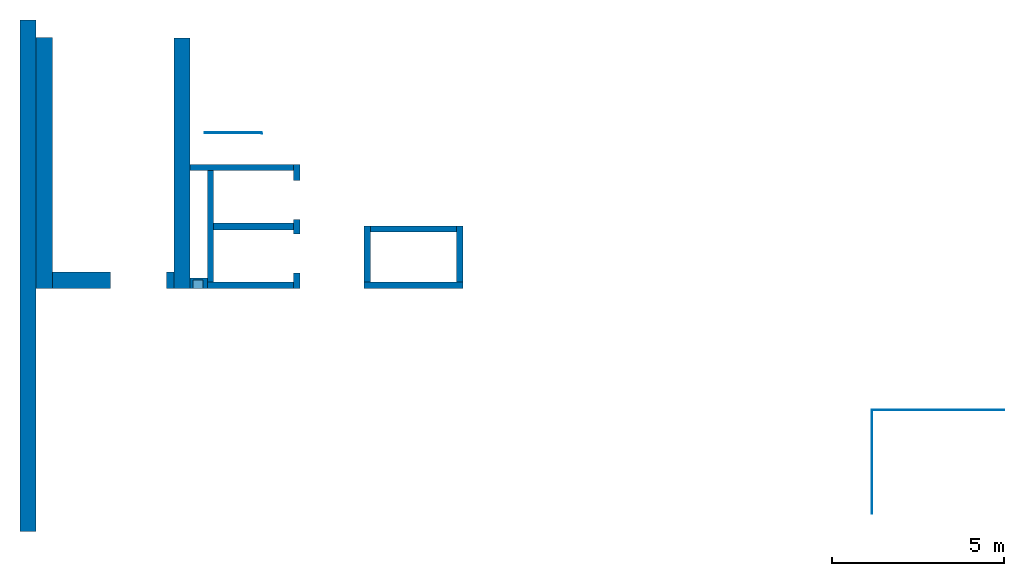
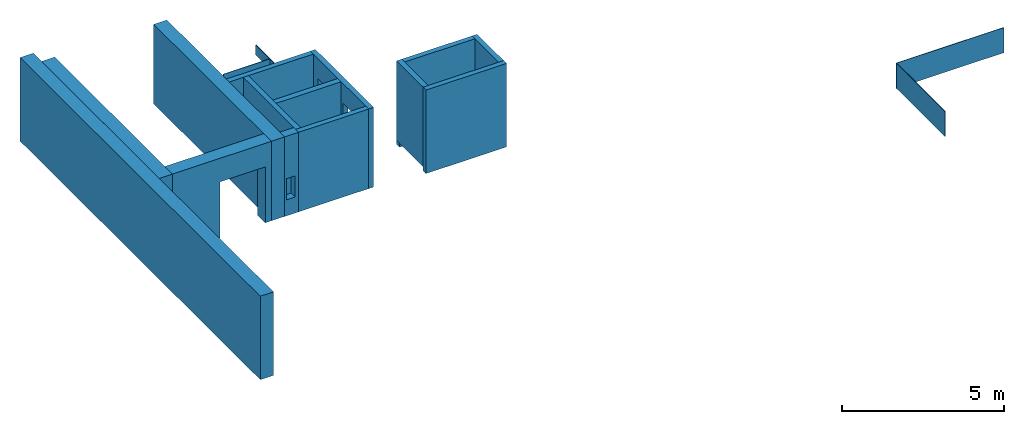
# One storey: 18 walls, 6 openings.
"""IFC4 building model written with IfcOpenShell, lengths in metres."""

import ifcopenshell
import ifcopenshell.guid

model = None  # the IFC model being written
_history = None  # IfcOwnerHistory: only IFC2X3 demands one
_inside = {}  # id of a spatial element -> (the spatial element, [elements in it])
_under = {}  # id of a project, library or spatial element -> (it, [spatial elements below it])
_declared = {}  # id of a project -> (the project, [libraries it declares])
_typed = {}  # id of a type object -> (the type object, [elements of that type])
_made_of = {}  # id of a material, layer set ... -> (it, [elements and type objects made of it])


def new_model(schema):
    """Start an empty IFC model of exactly this schema.

    Asked for "IFC4X3", IfcOpenShell would pick the latest addendum, in which some entities
    have other attributes; the version numbers below select the first issue.
    IFC2X3 requires an IfcOwnerHistory on every rooted entity: one is made here for all.
    """
    global model, _history
    if schema == "IFC4X3":
        model = ifcopenshell.file(schema_version=(4, 3, 0, 0))
    else:
        model = ifcopenshell.file(schema=schema)
    _inside.clear()
    _under.clear()
    _declared.clear()
    _typed.clear()
    _made_of.clear()
    _history = None
    if model.schema == "IFC2X3":
        org = make("IfcOrganization", Name="unknown")
        user = make(
            "IfcPersonAndOrganization",
            ThePerson=make("IfcPerson", FamilyName="unknown"),
            TheOrganization=org,
        )
        app = make(
            "IfcApplication",
            ApplicationDeveloper=org,
            Version="unknown",
            ApplicationFullName="unknown",
            ApplicationIdentifier="unknown",
        )
        _history = make(
            "IfcOwnerHistory",
            OwningUser=user,
            OwningApplication=app,
            ChangeAction="ADDED",
            CreationDate=0,
        )
    return model


def make(cls, **values):
    """One entity of the class cls with the attributes given. An attribute that is None is left unset."""
    return model.create_entity(
        cls, **{name: value for name, value in values.items() if value is not None}
    )


def entity(cls, *values):
    """Any entity or typed value of the class cls, its attributes in the order of the schema. None: left unset."""
    e = model.create_entity(cls)
    for i, value in enumerate(values):
        if value is not None:
            e[i] = value
    return e


def rooted(cls, **values):
    """An entity with a GlobalId (a new one), such as an element, a storey or a relation."""
    return make(cls, GlobalId=ifcopenshell.guid.new(), OwnerHistory=_history, **values)


def si_unit(unit_type, name, prefix=None):
    """IfcSIUnit, for example si_unit("LENGTHUNIT", "METRE", prefix="MILLI")."""
    return make("IfcSIUnit", UnitType=unit_type, Prefix=prefix, Name=name)


def converted_unit(unit_type, name, factor, base, dimensions=None, offset=None):
    """IfcConversionBasedUnit, such as the inch: factor (a typed value) times the base unit."""
    return make(
        "IfcConversionBasedUnit"
        if offset is None
        else "IfcConversionBasedUnitWithOffset",
        ConversionOffset=offset,
        Dimensions=None
        if dimensions is None
        else entity("IfcDimensionalExponents", *dimensions),
        UnitType=unit_type,
        Name=name,
        ConversionFactor=make(
            "IfcMeasureWithUnit", ValueComponent=factor, UnitComponent=base
        ),
    )


def derived_unit(unit_type, elements):
    """IfcDerivedUnit: a product of units, each with its exponent."""
    return make(
        "IfcDerivedUnit",
        Elements=[
            make("IfcDerivedUnitElement", Unit=unit, Exponent=power)
            for unit, power in elements
        ],
        UnitType=unit_type,
    )


def assignment(units):
    """IfcUnitAssignment: the units of a project."""
    return None if units is None else make("IfcUnitAssignment", Units=units)


def point(xyz):
    """IfcCartesianPoint."""
    return None if xyz is None else make("IfcCartesianPoint", Coordinates=xyz)


def direction(xyz):
    """IfcDirection."""
    return None if xyz is None else make("IfcDirection", DirectionRatios=xyz)


def frame(location, z_axis=None, x_axis=None):
    """IfcAxis2Placement3D, a coordinate frame: its origin and axes. An axis left out is left unset."""
    return make(
        "IfcAxis2Placement3D",
        Location=point(location),
        Axis=direction(z_axis),
        RefDirection=direction(x_axis),
    )


def origin_with_axes():
    """The frame at (0, 0, 0) with the z axis (0, 0, 1) and the x axis (1, 0, 0) written out."""
    return frame((0.0, 0.0, 0.0), z_axis=(0.0, 0.0, 1.0), x_axis=(1.0, 0.0, 0.0))


def place(relative_to, where):
    """IfcLocalPlacement: puts the frame where relative to a parent placement (None: the world)."""
    return make(
        "IfcLocalPlacement", PlacementRelTo=relative_to, RelativePlacement=where
    )


def context(
    kind, dimensions, precision=None, world=None, true_north=None, identifier=None
):
    """IfcGeometricRepresentationContext, for example the 3D "Model" context."""
    return make(
        "IfcGeometricRepresentationContext",
        ContextIdentifier=identifier,
        ContextType=kind,
        CoordinateSpaceDimension=dimensions,
        Precision=precision,
        WorldCoordinateSystem=world,
        TrueNorth=true_north,
    )


def subcontext(parent, identifier, kind, view, scale=None):
    """IfcGeometricRepresentationSubContext, for example "Body" below "Model"."""
    return make(
        "IfcGeometricRepresentationSubContext",
        ContextIdentifier=identifier,
        ContextType=kind,
        ParentContext=parent,
        TargetScale=scale,
        TargetView=view,
    )


def project(units=None, contexts=None):
    """IfcProject with its units and contexts."""
    return rooted(
        "IfcProject",
        Name="project",
        RepresentationContexts=contexts,
        UnitsInContext=assignment(units),
    )


def spatial(cls, under=None, at=None, **own):
    """A site, building, storey or space (cls), placed at a placement, below another one or the project."""
    s = rooted(cls, ObjectPlacement=at, **own)
    if under is not None:
        _under.setdefault(under.id(), (under, []))[1].append(s)
    return s


def point_list(points):
    """IfcCartesianPointList2D or 3D."""
    cls = (
        "IfcCartesianPointList2D" if len(points[0]) == 2 else "IfcCartesianPointList3D"
    )
    return make(cls, CoordList=points)


def polygons(points, faces, closed=None, point_numbers=None):
    """IfcPolygonalFaceSet: a face is its outer loop, then its inner loops; points numbered from 1."""
    made = []
    for loops in faces:
        if len(loops) == 1:
            made.append(make("IfcIndexedPolygonalFace", CoordIndex=loops[0]))
        else:
            made.append(
                make(
                    "IfcIndexedPolygonalFaceWithVoids",
                    CoordIndex=loops[0],
                    InnerCoordIndices=loops[1:],
                )
            )
    return make(
        "IfcPolygonalFaceSet",
        Coordinates=point_list(points),
        Closed=closed,
        Faces=made,
        PnIndex=point_numbers,
    )


def shape(context_of_items, identifier, shape_type, items):
    """IfcShapeRepresentation: the items that make up one representation, for example the "Body"."""
    return make(
        "IfcShapeRepresentation",
        ContextOfItems=context_of_items,
        RepresentationIdentifier=identifier,
        RepresentationType=shape_type,
        Items=items,
    )


def material(Name=None, Category=None):
    """IfcMaterial."""
    return make("IfcMaterial", Name=Name, Category=Category)


def made_of(thing, what):
    """Note that an element or type object is made of a material, layer set ...; save() writes the relation."""
    if what is not None:
        _made_of.setdefault(what.id(), (what, []))[1].append(thing)
    return thing


def type_object(cls, material=None, **own):
    """A type object (cls), such as IfcWallType, which elements share."""
    return made_of(rooted(cls, **own), material)


def element(
    cls,
    number,
    at=None,
    inside=None,
    cuts=None,
    type_object=None,
    material=None,
    context=None,
    identifier="Body",
    shape_type=None,
    held_by="IfcProductDefinitionShape",
    body=None,
    shapes=None,
    **own,
):
    """One element of the class cls, such as IfcWall. Its Tag is "e" and its number.

    at: its placement. inside: the storey or other place that contains it. cuts: it is an
    opening in that element (IfcRelVoidsElement). A single representation is given by context,
    identifier, shape_type and body (its items); several are given by shapes. held_by: the class
    of the entity that holds the representations. save() writes the other relations.
    """
    e = rooted(cls, Tag="e%d" % number, ObjectPlacement=at, **own)
    if body is not None:
        shapes = [shape(context, identifier, shape_type, body)]
    if shapes is not None:
        e.Representation = make(held_by, Representations=shapes)
    if inside is not None:
        _inside.setdefault(inside.id(), (inside, []))[1].append(e)
    if cuts is not None:
        rooted(
            "IfcRelVoidsElement", RelatingBuildingElement=cuts, RelatedOpeningElement=e
        )
    if type_object is not None:
        _typed.setdefault(type_object.id(), (type_object, []))[1].append(e)
    return made_of(e, material)


def aggregate(whole, parts):
    """IfcRelAggregates: a whole, such as a stair, and the parts it consists of."""
    return rooted("IfcRelAggregates", RelatingObject=whole, RelatedObjects=parts)


def save(model, path):
    """Write the relations noted so far, then the file.

    IfcRelAggregates (storeys below a building ...), IfcRelContainedInSpatialStructure (elements
    in a storey), IfcRelDefinesByType, IfcRelAssociatesMaterial and IfcRelDeclares: one each for
    every whole, place, type object, material and project.
    """
    for whole, parts in _under.values():
        aggregate(whole, parts)
    for where, things in _inside.values():
        rooted(
            "IfcRelContainedInSpatialStructure",
            RelatedElements=things,
            RelatingStructure=where,
        )
    for kind, things in _typed.values():
        rooted("IfcRelDefinesByType", RelatedObjects=things, RelatingType=kind)
    for what, things in _made_of.values():
        rooted("IfcRelAssociatesMaterial", RelatedObjects=things, RelatingMaterial=what)
    for by, libraries in _declared.values():
        rooted("IfcRelDeclares", RelatingContext=by, RelatedDefinitions=libraries)
    model.write(path)


model = new_model("IFC4")

# Units and contexts
model_context = context("Model", 3, precision=1e-05, world=origin_with_axes(), true_north=direction((0.0, 1.0)))
body_context = subcontext(model_context, "Body", "Model", "MODEL_VIEW")
ifc_project = project(units=[si_unit("LENGTHUNIT", "METRE"), si_unit("AREAUNIT", "SQUARE_METRE"), si_unit("VOLUMEUNIT", "CUBIC_METRE"), converted_unit("PLANEANGLEUNIT", "DEGREE", entity("IfcPlaneAngleMeasure", 0.0174532925199433), si_unit("PLANEANGLEUNIT", "RADIAN"), dimensions=[0, 0, 0, 0, 0, 0, 0]), converted_unit("TIMEUNIT", "Year", entity("IfcTimeMeasure", 31557600.0), si_unit("TIMEUNIT", "SECOND"), dimensions=[0, 0, 1, 0, 0, 0, 0]), si_unit("MASSUNIT", "GRAM", prefix="KILO"), si_unit("THERMODYNAMICTEMPERATUREUNIT", "DEGREE_CELSIUS"), si_unit("LUMINOUSINTENSITYUNIT", "LUMEN"), si_unit("ENERGYUNIT", "JOULE", prefix="MEGA"), derived_unit("THERMALCONDUCTANCEUNIT", [(si_unit("POWERUNIT", "WATT"), 1), (si_unit("LENGTHUNIT", "METRE"), -1), (si_unit("THERMODYNAMICTEMPERATUREUNIT", "KELVIN"), -1)]), derived_unit("SPECIFICHEATCAPACITYUNIT", [(si_unit("ENERGYUNIT", "JOULE"), 1), (si_unit("MASSUNIT", "GRAM", prefix="KILO"), -1), (si_unit("THERMODYNAMICTEMPERATUREUNIT", "KELVIN"), -1)]), derived_unit("MASSDENSITYUNIT", [(si_unit("MASSUNIT", "GRAM", prefix="KILO"), 1), (si_unit("VOLUMEUNIT", "CUBIC_METRE"), -1)])], contexts=[model_context])

# Site, building, storey
site_placement = place(None, origin_with_axes())
site = spatial("IfcSite", under=ifc_project, at=site_placement, CompositionType="ELEMENT")
building_placement = place(None, origin_with_axes())
building = spatial("IfcBuilding", under=site, at=building_placement, CompositionType="ELEMENT")
storey_placement = place(None, frame((0.0, 0.0, 4.5), z_axis=(0.0, 0.0, 1.0), x_axis=(1.0, 0.0, 0.0)))
storey = spatial("IfcBuildingStorey", under=building, at=storey_placement, Name="1 OG", CompositionType="ELEMENT", Elevation=4.5)

# Walls
ifc_material_1 = material(Name="Stahlbeton")
wall_type_1 = type_object("IfcWallType", Name="Stahlbeton 180", PredefinedType="NOTDEFINED")
wall_1_placement = place(None, frame((36.373, 7.05499994546756, 4.5), z_axis=(0.0, 0.0, 1.0), x_axis=(0.0, 1.0, 0.0)))
element("IfcWall", 1, at=wall_1_placement, inside=storey, type_object=wall_type_1, material=ifc_material_1, Name="Wand-001", PredefinedType="NOTDEFINED", context=body_context, shape_type="Tessellation", body=[
    polygons([(1.818, 0.18, 0.0), (1.818, 0.0, 0.0), (0.18, 0.0, 0.0), (0.18, 0.18, 0.0), (1.818, 0.18, 3.0), (1.818, 0.0, 3.0), (0.18, 0.0, 3.0), (0.18, 0.18, 3.0)], [[[1, 2, 3, 4]], [[2, 1, 5, 6]], [[2, 6, 7, 3]], [[8, 4, 3, 7]], [[5, 1, 4, 8]], [[6, 5, 8, 7]]], closed=True),
])
wall_2_placement = place(None, frame((28.958, 7.05499994546755, 4.5), z_axis=(0.0, 0.0, 1.0), x_axis=(1.0, 0.0, 0.0)))
element("IfcWall", 2, at=wall_2_placement, inside=storey, type_object=wall_type_1, material=ifc_material_1, Name="Wand-001", PredefinedType="NOTDEFINED", context=body_context, shape_type="Tessellation", body=[
    polygons([(2.5, 0.180000000000001, 0.0), (2.5, 0.0, 0.0), (0.0, 0.0, 0.0), (0.0, 0.18, 0.0), (2.5, 0.180000000000001, 3.0), (2.5, 0.0, 3.0), (0.0, 0.0, 3.0), (0.0, 0.180000000000001, 3.0)], [[[1, 2, 3, 4]], [[2, 1, 5, 6]], [[2, 6, 7, 3]], [[8, 4, 3, 7]], [[5, 1, 4, 8]], [[6, 5, 8, 7]]], closed=True),
])
wall_3_placement = place(None, frame((33.505, 7.05499994546756, 4.5), z_axis=(0.0, 0.0, 1.0), x_axis=(0.0, 1.0, 0.0)))
element("IfcWall", 3, at=wall_3_placement, inside=storey, type_object=wall_type_1, material=ifc_material_1, Name="Wand-001", PredefinedType="NOTDEFINED", context=body_context, shape_type="Tessellation", body=[
    polygons([(1.818, -0.18, 3.0), (1.818, 0.0, 3.0), (0.18, 0.0, 3.0), (0.18, -0.18, 3.0), (1.818, -0.18, 0.0), (1.818, 0.0, 0.0), (0.18, 0.0, 0.0), (0.18, -0.18, 0.0)], [[[1, 2, 3, 4]], [[2, 1, 5, 6]], [[2, 6, 7, 3]], [[8, 4, 3, 7]], [[5, 1, 4, 8]], [[6, 5, 8, 7]]], closed=True),
])

# Wall, openings
wall_4_placement = place(None, frame((31.638, 7.05499994546755, 4.5), z_axis=(0.0, 0.0, 1.0), x_axis=(0.0, 1.0, 0.0)))
wall_4 = element("IfcWall", 4, at=wall_4_placement, inside=storey, type_object=wall_type_1, material=ifc_material_1, Name="Wand-002", PredefinedType="NOTDEFINED", context=body_context, shape_type="Tessellation", body=[
    polygons([(2.0, 0.0, 0.0), (2.0, 0.0, 2.25), (3.13, 0.0, 2.25), (3.13, 0.0, 0.0), (3.6, 0.0, 0.0), (3.6, 0.0, 3.0), (0.0, 0.0, 3.0), (0.0, 0.0, 0.0), (0.450000000000002, 0.0, 0.0), (0.450000000000002, 0.0, 2.25), (1.58, 0.0, 2.25), (1.58, 0.0, 0.0), (2.0, 0.179999999999996, 0.0), (2.0, 0.179999999999996, 2.25), (3.13, 0.179999999999996, 2.25), (3.13, 0.179999999999996, 0.0), (3.6, 0.179999999999996, 0.0), (3.6, 0.179999999999996, 3.0), (0.0, 0.18, 3.0), (0.0, 0.18, 0.0), (0.450000000000002, 0.18, 0.0), (0.450000000000002, 0.18, 2.25), (1.58, 0.18, 2.25), (1.58, 0.18, 0.0)], [[[1, 2, 3, 4, 5, 6, 7, 8, 9, 10, 11, 12]], [[2, 1, 13, 14]], [[3, 2, 14, 15]], [[4, 3, 15, 16]], [[4, 16, 17, 5]], [[18, 6, 5, 17]], [[19, 7, 6, 18]], [[8, 7, 19, 20]], [[9, 8, 20, 21]], [[9, 21, 22, 10]], [[10, 22, 23, 11]], [[11, 23, 24, 12]], [[13, 1, 12, 24]], [[14, 13, 24, 23, 22, 21, 20, 19, 18, 17, 16, 15]]], closed=True),
])
opening_1_placement = place(wall_4_placement, frame((1.015, 0.0, 0.0), z_axis=(0.0, 0.0, 1.0), x_axis=(1.0, 0.0, 0.0)))
element("IfcOpeningElement", 5, at=opening_1_placement, cuts=wall_4, context=body_context, identifier="Reference", shape_type="Tessellation", body=[
    polygons([(-0.565, -0.00100000000000122, 2.25), (-0.565, -0.00100000000000122, 0.0), (0.565, -0.00100000000000122, 0.0), (0.565, -0.00100000000000122, 2.25), (-0.565, 0.181000000000004, 2.25), (-0.565, 0.181000000000004, 0.0), (0.565000000000001, 0.181000000000004, 0.0), (0.565000000000001, 0.181000000000004, 2.25)], [[[1, 2, 3, 4]], [[5, 6, 2, 1]], [[6, 7, 3, 2]], [[7, 8, 4, 3]], [[8, 5, 1, 4]], [[7, 6, 5, 8]]], closed=True),
])
opening_2_placement = place(wall_4_placement, frame((2.565, 0.0, 0.0), z_axis=(0.0, 0.0, 1.0), x_axis=(1.0, 0.0, 0.0)))
element("IfcOpeningElement", 6, at=opening_2_placement, cuts=wall_4, context=body_context, identifier="Reference", shape_type="Tessellation", body=[
    polygons([(-0.565, -0.00100000000000478, 2.25), (-0.565, -0.00100000000000478, 0.0), (0.565, -0.00100000000000478, 0.0), (0.565, -0.00100000000000478, 2.25), (-0.564999999999998, 0.181000000000001, 2.25), (-0.564999999999998, 0.181000000000001, 0.0), (0.565000000000001, 0.181000000000001, 0.0), (0.565000000000001, 0.181000000000001, 2.25)], [[[1, 2, 3, 4]], [[5, 6, 2, 1]], [[6, 7, 3, 2]], [[7, 8, 4, 3]], [[8, 5, 1, 4]], [[7, 6, 5, 8]]], closed=True),
])

# Walls
wall_5_placement = place(None, frame((31.638, 10.6549999454676, 4.5), z_axis=(0.0, 0.0, 1.0), x_axis=(-1.0, 0.0, 0.0)))
element("IfcWall", 7, at=wall_5_placement, inside=storey, type_object=wall_type_1, material=ifc_material_1, Name="Wand-003", PredefinedType="NOTDEFINED", context=body_context, shape_type="Tessellation", body=[
    polygons([(3.18, 0.18, 0.0), (3.18, 0.0, 0.0), (0.18, 0.0, 0.0), (0.18, 0.18, 0.0), (3.18, 0.18, 3.0), (3.18, 0.0, 3.0), (0.18, 0.0, 3.0), (0.18, 0.18, 3.0)], [[[1, 2, 3, 4]], [[2, 1, 5, 6]], [[2, 6, 7, 3]], [[8, 4, 3, 7]], [[5, 1, 4, 8]], [[6, 5, 8, 7]]], closed=True),
])
wall_6_placement = place(None, frame((36.373, 8.87299994546756, 4.35), z_axis=(0.0, 0.0, 1.0), x_axis=(-1.0, 0.0, 0.0)))
element("IfcWall", 8, at=wall_6_placement, inside=storey, type_object=wall_type_1, material=ifc_material_1, Name="Wand-001", PredefinedType="NOTDEFINED", context=body_context, shape_type="Tessellation", body=[
    polygons([(2.688, 0.0, 3.15), (0.18, 0.0, 3.15), (0.18, 0.0, 0.15), (0.0, 0.0, 0.15), (0.0, 0.0, 0.0), (2.868, 0.0, 0.0), (2.868, 0.0, 0.15), (2.688, 0.0, 0.15), (2.688, 0.18, 3.15), (0.18, 0.18, 3.15), (0.18, 0.18, 0.15), (0.0, 0.18, 0.15), (0.0, 0.18, 0.0), (2.868, 0.18, 0.0), (2.868, 0.18, 0.15), (2.688, 0.18, 0.15)], [[[1, 2, 3, 4, 5, 6, 7, 8]], [[9, 10, 2, 1]], [[11, 3, 2, 10]], [[11, 12, 4, 3]], [[5, 4, 12, 13]], [[5, 13, 14, 6]], [[14, 15, 7, 6]], [[16, 8, 7, 15]], [[16, 9, 1, 8]], [[12, 11, 10, 9, 16, 15, 14, 13]]], closed=True),
])
wall_7_placement = place(None, frame((33.505, 7.05499994546756, 4.35), z_axis=(0.0, 0.0, 1.0), x_axis=(1.0, 0.0, 0.0)))
element("IfcWall", 9, at=wall_7_placement, inside=storey, type_object=wall_type_1, material=ifc_material_1, Name="Wand-001", PredefinedType="NOTDEFINED", context=body_context, shape_type="Tessellation", body=[
    polygons([(2.868, 0.0, 3.15), (2.868, 0.0, 0.15), (2.868, 0.18, 0.15), (2.868, 0.180000000000001, 3.15), (0.0, 0.0, 0.0), (2.868, 0.0, 0.0), (0.0, 0.0, 3.15), (0.0, 0.0, 0.15), (2.868, 0.18, 0.0), (0.0, 0.18, 0.0), (0.0, 0.18, 0.15), (0.0, 0.180000000000001, 3.15)], [[[1, 2, 3, 4]], [[5, 6, 2, 1, 7, 8]], [[6, 9, 3, 2]], [[4, 3, 9, 10, 11, 12]], [[7, 1, 4, 12]], [[10, 9, 6, 5]], [[12, 11, 8, 7]], [[5, 8, 11, 10]]], closed=True),
])
wall_8_placement = place(None, frame((29.138, 7.05499994546755, 4.5), z_axis=(0.0, 0.0, 1.0), x_axis=(0.0, 1.0, 0.0)))
element("IfcWall", 10, at=wall_8_placement, inside=storey, type_object=wall_type_1, material=ifc_material_1, Name="Wand-003", PredefinedType="NOTDEFINED", context=body_context, shape_type="Tessellation", body=[
    polygons([(3.42, 0.18, 0.0), (3.42, 0.0, 0.0), (0.18, 0.0, 0.0), (0.18, 0.18, 0.0), (3.42, 0.18, 3.0), (3.42, 0.0, 3.0), (0.18, 0.0, 3.0), (0.18, 0.18, 3.0)], [[[1, 2, 3, 4]], [[2, 1, 5, 6]], [[2, 6, 7, 3]], [[8, 4, 3, 7]], [[5, 1, 4, 8]], [[6, 5, 8, 7]]], closed=True),
])

# Space
space_placement = place(None, frame((28.883, 12.4404999136732, 4.5), z_axis=(0.0, 0.0, 1.0), x_axis=(0.0, -1.0, 0.0)))
space = spatial("IfcSpace", under=storey, at=space_placement, CompositionType="ELEMENT", PredefinedType="NOTDEFINED")

# Wall, openings
ifc_material_2 = material(Name="Kunststoff")
wall_type_2 = type_object("IfcWallType", Name="Kunststoff 20", PredefinedType="NOTDEFINED")
wall_9_placement = place(None, frame((30.553, 10.6549999454676, 4.35), z_axis=(0.0, 0.0, 1.0), x_axis=(0.0, 1.0, 0.0)))
wall_9 = element("IfcWall", 11, at=wall_9_placement, inside=space, type_object=wall_type_2, material=ifc_material_2, Name="Wand-003", PredefinedType="NOTDEFINED", context=body_context, shape_type="Tessellation", body=[
    polygons([(0.895499968205613, 0.0, 0.15), (0.895499968205613, 0.0, 2.245), (1.78549996820561, 0.0, 2.245), (1.78549996820561, 0.0, 2.63), (0.0, 0.0, 2.63), (0.0, 0.0, 2.245), (0.890000000000001, 0.0, 2.245), (0.890000000000001, 0.0, 0.15), (0.895499968205613, 0.0199999999999996, 0.15), (0.895499968205613, 0.0199999999999996, 2.245), (1.78549996820561, 0.0199999999999996, 2.245), (1.78549996820561, 0.0199999999999996, 2.63), (0.0, 0.0199999999999996, 2.63), (0.0, 0.0199999999999996, 2.245), (0.890000000000001, 0.0199999999999996, 2.245), (0.890000000000001, 0.0199999999999996, 0.15)], [[[1, 2, 3, 4, 5, 6, 7, 8]], [[2, 1, 9, 10]], [[11, 3, 2, 10]], [[3, 11, 12, 4]], [[13, 5, 4, 12]], [[6, 5, 13, 14]], [[6, 14, 15, 7]], [[7, 15, 16, 8]], [[9, 1, 8, 16]], [[10, 9, 16, 15, 14, 13, 12, 11]]], closed=True),
])
opening_3_placement = place(wall_9_placement, frame((1.34049996820561, 0.0, 0.2), z_axis=(0.0, 0.0, 1.0), x_axis=(1.0, 0.0, 0.0)))
element("IfcOpeningElement", 12, at=opening_3_placement, cuts=wall_9, context=body_context, identifier="Reference", shape_type="Tessellation", body=[
    polygons([(0.445, 0.0210000000000008, 2.045), (0.445, 0.0210000000000008, -0.0499999999999998), (-0.445, 0.0210000000000008, -0.0499999999999998), (-0.445, 0.0210000000000008, 2.045), (0.445, -0.00100000000000122, 2.045), (0.445, -0.00100000000000122, -0.0499999999999998), (-0.445, -0.00100000000000122, -0.0499999999999998), (-0.445, -0.00100000000000122, 2.045)], [[[1, 2, 3, 4]], [[5, 6, 2, 1]], [[6, 7, 3, 2]], [[7, 8, 4, 3]], [[8, 5, 1, 4]], [[7, 6, 5, 8]]], closed=True),
])
opening_4_placement = place(wall_9_placement, frame((0.445, 0.0, 0.2), z_axis=(0.0, 0.0, 1.0), x_axis=(1.0, 0.0, 0.0)))
element("IfcOpeningElement", 13, at=opening_4_placement, cuts=wall_9, context=body_context, identifier="Reference", shape_type="Tessellation", body=[
    polygons([(0.445, 0.0210000000000008, 2.045), (0.445, 0.0210000000000008, -0.0499999999999998), (-0.445, 0.0210000000000008, -0.0499999999999998), (-0.445, 0.0210000000000008, 2.045), (0.445, -0.00100000000000122, 2.045), (0.445, -0.00100000000000122, -0.0499999999999998), (-0.445, -0.00100000000000122, -0.0499999999999998), (-0.445, -0.00100000000000122, 2.045)], [[[1, 2, 3, 4]], [[5, 6, 2, 1]], [[6, 7, 3, 2]], [[7, 8, 4, 3]], [[8, 5, 1, 4]], [[7, 6, 5, 8]]], closed=True),
])

# Walls
wall_10_placement = place(None, frame((30.553, 11.5727499295704, 4.35), z_axis=(0.0, 0.0, 1.0), x_axis=(-1.0, 0.0, 0.0)))
element("IfcWall", 14, at=wall_10_placement, inside=space, type_object=wall_type_2, material=ifc_material_2, Name="Wand-003", PredefinedType="NOTDEFINED", context=body_context, shape_type="Tessellation", body=[
    polygons([(0.0199999999999996, -0.00999999999999979, 2.63), (0.0199999999999996, 0.00999999999999979, 2.63), (0.0199999999999996, 0.00999999999999979, 0.15), (0.0199999999999996, -0.00999999999999979, 0.15), (1.67, -0.00999999999999979, 2.63), (1.67, 0.00999999999999979, 2.63), (1.67, 0.00999999999999979, 0.15), (1.67, -0.00999999999999979, 0.15)], [[[1, 2, 3, 4]], [[2, 1, 5, 6]], [[2, 6, 7, 3]], [[3, 7, 8, 4]], [[5, 1, 4, 8]], [[6, 5, 8, 7]]], closed=True),
])
wall_type_3 = type_object("IfcWallType", Name="Stahlbeton 470", PredefinedType="NOTDEFINED")
wall_11_placement = place(None, frame((23.988, 14.8459998818788, 4.35), z_axis=(0.0, 0.0, 1.0), x_axis=(0.0, -1.0, 0.0)))
element("IfcWall", 15, at=wall_11_placement, inside=storey, type_object=wall_type_3, material=ifc_material_1, Name="Wand-001", PredefinedType="NOTDEFINED", context=body_context, shape_type="Tessellation", body=[
    polygons([(0.0, 0.0, 0.0), (0.0, 0.0, 3.15), (14.8459998818788, 0.0, 3.15), (14.8459998818788, 0.0, 0.0), (0.362999951604566, 0.0, 3.0), (0.362999951604566, 0.0, 2.63), (7.79099993641123, 0.0, 2.63), (14.4829998291425, 0.0, 2.63), (14.4829998291425, 0.0, 3.0), (7.79099993641123, 0.0, 3.0), (0.0, -0.469999999999999, 0.0), (0.0, -0.469999999999999, 3.15), (14.8459998818788, -0.469999999999999, 3.15), (14.8459998818788, -0.469999999999999, 0.0), (0.362999951604566, -0.100000000000008, 2.63), (0.362999951604566, -0.100000000000008, 3.0), (14.4829998289544, -0.100000000000008, 2.63), (14.4829998289544, -0.100000000000008, 3.0)], [[[1, 2, 3, 4], [5, 6, 7, 8, 9, 10]], [[1, 11, 12, 2]], [[2, 12, 13, 3]], [[4, 3, 13, 14]], [[11, 1, 4, 14]], [[15, 6, 5, 16]], [[8, 7, 6, 15, 17]], [[18, 9, 8, 17]], [[18, 16, 5, 10, 9]], [[12, 11, 14, 13]], [[17, 15, 16, 18]]], closed=True),
])
wall_12_placement = place(None, frame((27.988, 14.3259998818788, 4.5), z_axis=(0.0, 0.0, 1.0), x_axis=(0.0, -1.0, 0.0)))
element("IfcWall", 16, at=wall_12_placement, inside=storey, type_object=wall_type_3, material=ifc_material_1, Name="Wand-001", PredefinedType="NOTDEFINED", context=body_context, shape_type="Tessellation", body=[
    polygons([(7.27099993641123, 0.469999999999999, 0.0), (7.27099993641123, 0.0, 0.0), (0.0, 0.0, 0.0), (0.0, 0.469999999999999, 0.0), (7.27099993641123, 0.469999999999999, 3.0), (7.27099993641123, 0.0, 3.0), (0.0, 0.0, 3.0), (0.0, 0.469999999999999, 3.0)], [[[1, 2, 3, 4]], [[2, 1, 5, 6]], [[2, 6, 7, 3]], [[8, 4, 3, 7]], [[5, 1, 4, 8]], [[6, 5, 8, 7]]], closed=True),
])

# Wall, opening
wall_13_placement = place(None, frame((24.458, 7.52499994546755, 4.5), z_axis=(0.0, 0.0, 1.0), x_axis=(1.0, 0.0, 0.0)))
wall_13 = element("IfcWall", 17, at=wall_13_placement, inside=storey, type_object=wall_type_3, material=ifc_material_1, Name="Wand-001", PredefinedType="NOTDEFINED", context=body_context, shape_type="Tessellation", body=[
    polygons([(1.69000000000001, 0.0, 2.11), (1.69000000000001, 0.0, 0.0), (0.0, 0.0, 0.0), (0.0, 0.0, 3.0), (3.53, 0.0, 3.0), (3.53, 0.0, 0.0), (3.31, 0.0, 0.0), (3.31, 0.0, 2.11), (1.69000000000001, -0.47, 2.11), (1.69000000000001, -0.47, 0.0), (0.0, -0.47, 0.0), (0.0, -0.47, 3.0), (3.53, -0.47, 3.0), (3.53, -0.47, 0.0), (3.31, -0.47, 0.0), (3.31, -0.47, 2.11)], [[[1, 2, 3, 4, 5, 6, 7, 8]], [[2, 1, 9, 10]], [[2, 10, 11, 3]], [[12, 4, 3, 11]], [[5, 4, 12, 13]], [[13, 14, 6, 5]], [[15, 7, 6, 14]], [[8, 7, 15, 16]], [[1, 8, 16, 9]], [[16, 15, 14, 13, 12, 11, 10, 9]]], closed=True),
])
opening_5_placement = place(wall_13_placement, frame((2.5, 0.0, 0.0), z_axis=(0.0, 0.0, 1.0), x_axis=(1.0, 0.0, 0.0)))
element("IfcOpeningElement", 18, at=opening_5_placement, cuts=wall_13, context=body_context, identifier="Reference", shape_type="Tessellation", body=[
    polygons([(-0.809999999999999, -0.471, 2.11), (-0.809999999999999, -0.471, 0.0), (0.809999999999999, -0.471, 0.0), (0.809999999999999, -0.471, 2.11), (-0.809999999999999, 0.00100000000000033, 2.11), (-0.809999999999999, 0.00100000000000033, 0.0), (0.809999999999999, 0.00100000000000033, 0.0), (0.809999999999999, 0.00100000000000033, 2.11)], [[[1, 2, 3, 4]], [[5, 6, 2, 1]], [[6, 7, 3, 2]], [[7, 8, 4, 3]], [[8, 5, 1, 4]], [[7, 6, 5, 8]]], closed=True),
])

# Wall
wall_14_placement = place(None, frame((24.458, 14.3318657372406, 4.5), z_axis=(0.0, 0.0, 1.0), x_axis=(0.0, -1.0, 0.0)))
element("IfcWall", 19, at=wall_14_placement, inside=storey, type_object=wall_type_3, material=ifc_material_1, Name="Wand-001", PredefinedType="NOTDEFINED", context=body_context, shape_type="Tessellation", body=[
    polygons([(7.27686579177299, -0.470000000000002, 3.0), (7.27686579177299, 0.0, 3.0), (0.0, 0.0, 3.0), (0.0, -0.469999999999999, 3.0), (7.27686579177299, -0.470000000000002, 0.0), (7.27686579177299, 0.0, 0.0), (0.0, 0.0, 0.0), (0.0, -0.469999999999999, 0.0)], [[[1, 2, 3, 4]], [[2, 1, 5, 6]], [[2, 6, 7, 3]], [[8, 4, 3, 7]], [[5, 1, 4, 8]], [[6, 5, 8, 7]]], closed=True),
])

# Wall, opening
wall_type_4 = type_object("IfcWallType", Name="Stahlbeton 300", PredefinedType="NOTDEFINED")
wall_15_placement = place(None, frame((28.458, 7.05499994546755, 4.5), z_axis=(0.0, 0.0, 1.0), x_axis=(1.0, 0.0, 0.0)))
wall_15 = element("IfcWall", 20, at=wall_15_placement, inside=storey, type_object=wall_type_4, material=ifc_material_1, Name="Wand-001", PredefinedType="NOTDEFINED", context=body_context, shape_type="Tessellation", body=[
    polygons([(0.0, 0.0, 3.0), (0.0, 0.0, 0.0), (0.5, 0.0, 0.0), (0.5, 0.0, 3.0), (0.375425898351669, 0.0, 0.6), (0.0754258983516713, 0.0, 0.6), (0.0754258983516713, 0.0, 1.4), (0.375425898351669, 0.0, 1.4), (0.0, 0.3, 3.0), (0.0, 0.3, 0.0), (0.5, 0.3, 0.0), (0.5, 0.3, 3.0), (0.0754258983516713, 0.25, 0.6), (0.375425898351669, 0.25, 0.6), (0.0754258983516713, 0.25, 1.4), (0.375425898351669, 0.25, 1.4)], [[[1, 2, 3, 4], [5, 6, 7, 8]], [[1, 9, 10, 2]], [[2, 10, 11, 3]], [[4, 3, 11, 12]], [[9, 1, 4, 12]], [[13, 6, 5, 14]], [[15, 7, 6, 13]], [[16, 8, 7, 15]], [[14, 5, 8, 16]], [[10, 9, 12, 11]], [[13, 14, 16, 15]]], closed=True),
])
opening_6_placement = place(wall_15_placement, frame((-28.458, -7.05499994546755, -4.5), z_axis=(0.0, 0.0, 1.0), x_axis=(1.0, 0.0, 0.0)))
element("IfcOpeningElement", 21, at=opening_6_placement, cuts=wall_15, PredefinedType="NOTDEFINED", context=body_context, identifier="Reference", shape_type="Tessellation", body=[
    polygons([(28.5334258983517, 7.30499994546755, 5.1), (28.8334258983517, 7.30499994546755, 5.1), (28.8334258983517, 6.75499994546755, 5.1), (28.5334258983517, 6.75499994546755, 5.1), (28.5334258983517, 7.30499994546755, 5.9), (28.8334258983517, 7.30499994546755, 5.9), (28.8334258983517, 6.75499994546755, 5.9), (28.5334258983517, 6.75499994546755, 5.9)], [[[1, 2, 3, 4]], [[1, 5, 6, 2]], [[2, 6, 7, 3]], [[4, 3, 7, 8]], [[5, 1, 4, 8]], [[6, 5, 8, 7]]], closed=True),
])

# Walls
ifc_material_3 = material()
wall_type_5 = type_object("IfcWallType", Name="20", PredefinedType="NOTDEFINED")
wall_16_placement = place(None, frame((52.078, 3.52, 4.55), z_axis=(0.0, 0.0, 1.0), x_axis=(-1.0, 0.0, 0.0)))
element("IfcWall", 22, at=wall_16_placement, inside=storey, type_object=wall_type_5, material=ifc_material_3, Name="Wand-003", PredefinedType="NOTDEFINED", context=body_context, shape_type="Tessellation", body=[
    polygons([(3.84, 0.0, 0.95), (0.0, 0.0, 0.95), (0.0, -0.02, 0.95), (3.84, -0.0199999999999996, 0.95), (3.84, 0.0, 0.0), (0.0, 0.0, 0.0), (0.0, -0.02, 0.0), (3.84, -0.02, 0.0)], [[[1, 2, 3, 4]], [[5, 6, 2, 1]], [[3, 2, 6, 7]], [[4, 3, 7, 8]], [[4, 8, 5, 1]], [[8, 7, 6, 5]]], closed=True),
])
wall_17_placement = place(None, frame((48.258, 3.52, 4.55), z_axis=(0.0, 0.0, 1.0), x_axis=(0.0, -1.0, 0.0)))
element("IfcWall", 23, at=wall_17_placement, inside=storey, type_object=wall_type_5, material=ifc_material_3, Name="Wand-003", PredefinedType="NOTDEFINED", context=body_context, shape_type="Tessellation", body=[
    polygons([(3.0, -0.0200000000000031, 0.95), (3.0, 0.0, 0.95), (0.0, 0.0, 0.95), (0.0, -0.0200000000000031, 0.95), (3.0, -0.0200000000000031, 0.0), (3.0, 0.0, 0.0), (0.0, 0.0, 0.0), (0.0, -0.0200000000000031, 0.0)], [[[1, 2, 3, 4]], [[1, 5, 6, 2]], [[2, 6, 7, 3]], [[4, 3, 7, 8]], [[5, 1, 4, 8]], [[6, 5, 8, 7]]], closed=True),
])
wall_type_6 = type_object("IfcWallType", Name="Stahlbeton 200", PredefinedType="NOTDEFINED")
wall_18_placement = place(None, frame((29.138, 8.85499994546755, 4.5), z_axis=(0.0, 0.0, 1.0), x_axis=(1.0, 0.0, 0.0)))
element("IfcWall", 24, at=wall_18_placement, inside=storey, type_object=wall_type_6, material=ifc_material_1, Name="Wand-001", PredefinedType="NOTDEFINED", context=body_context, shape_type="Tessellation", body=[
    polygons([(2.32, 0.0999999999999996, 0.0), (2.32, -0.0999999999999996, 0.0), (0.0, -0.0999999999999996, 0.0), (0.0, 0.0999999999999996, 0.0), (2.32, 0.0999999999999996, 3.0), (2.32, -0.0999999999999996, 3.0), (0.0, -0.0999999999999996, 3.0), (0.0, 0.0999999999999996, 3.0)], [[[1, 2, 3, 4]], [[2, 1, 5, 6]], [[2, 6, 7, 3]], [[8, 4, 3, 7]], [[5, 1, 4, 8]], [[6, 5, 8, 7]]], closed=True),
])

save(model, "model.ifc")
